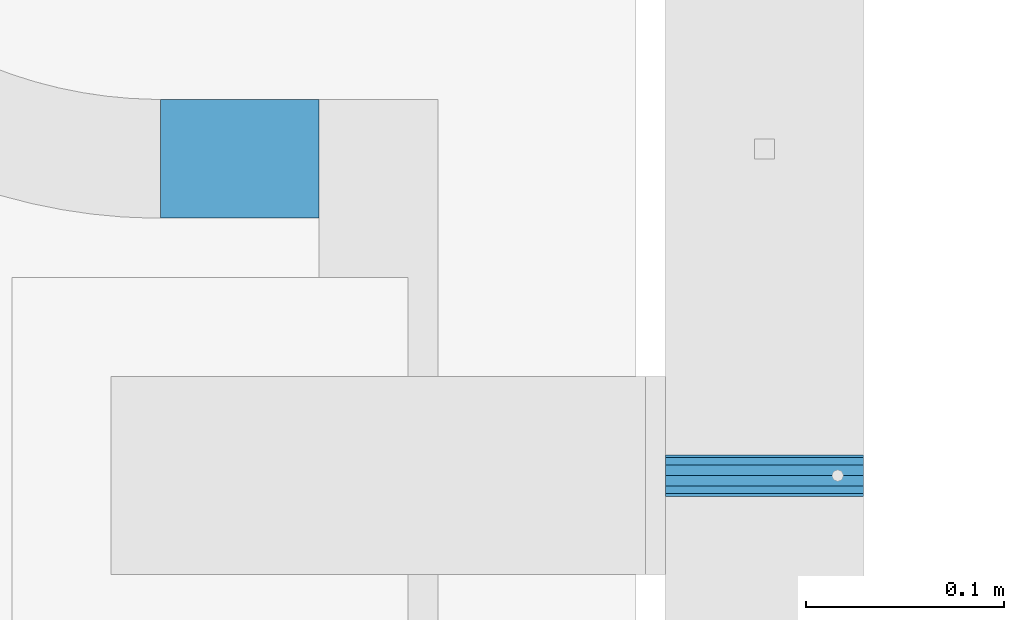
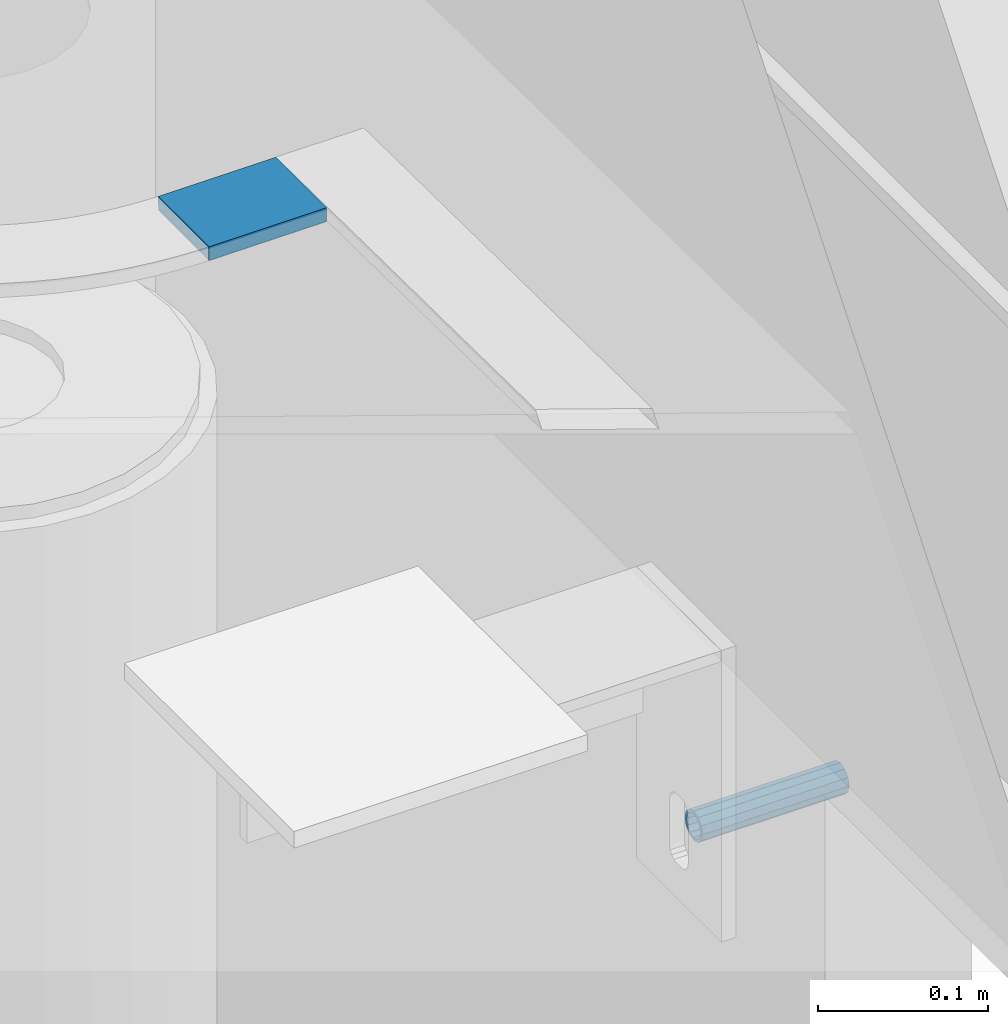
# One storey, part 115 of 264: 2 beams, 3 elements without a shape of their own.
"""IFC2X3 building model written with IfcOpenShell, lengths in millimetres."""

from ifc_helpers import new_model, si_unit, frame, origin_with_axes, place, context, subcontext, project, spatial, faceted_brep, material, type_object, element, aggregate, save


model = new_model("IFC2X3")

# Units and contexts
model_context = context("Model", 3, precision=1e-05, world=origin_with_axes())
body_context = subcontext(model_context, "Body", "Model", "MODEL_VIEW")
ifc_project = project(units=[si_unit("LENGTHUNIT", "METRE", prefix="MILLI"), si_unit("AREAUNIT", "SQUARE_METRE"), si_unit("VOLUMEUNIT", "CUBIC_METRE"), si_unit("MASSUNIT", "GRAM", prefix="KILO"), si_unit("TIMEUNIT", "SECOND"), si_unit("PLANEANGLEUNIT", "RADIAN"), si_unit("SOLIDANGLEUNIT", "STERADIAN"), si_unit("THERMODYNAMICTEMPERATUREUNIT", "DEGREE_CELSIUS"), si_unit("LUMINOUSINTENSITYUNIT", "LUMEN")], contexts=[model_context])

# Site, building, storey
site_placement = place(None, origin_with_axes())
site = spatial("IfcSite", under=ifc_project, at=site_placement, CompositionType="ELEMENT")
building_placement = place(site_placement, origin_with_axes())
building = spatial("IfcBuilding", under=site, at=building_placement, CompositionType="ELEMENT")
storey_placement = place(building_placement, origin_with_axes())
storey = spatial("IfcBuildingStorey", under=building, at=storey_placement, Name="K", CompositionType="ELEMENT", Elevation=0.0)

# Assemblies, beam
assembly_1_placement = place(storey_placement, origin_with_axes())
assembly_1 = element("IfcElementAssembly", 1, at=assembly_1_placement, inside=storey, AssemblyPlace="NOTDEFINED", PredefinedType="REINFORCEMENT_UNIT")
assembly_2_placement = place(assembly_1_placement, origin_with_axes())
assembly_2 = element("IfcElementAssembly", 2, at=assembly_2_placement, Name="Steel Assembly", AssemblyPlace="NOTDEFINED", PredefinedType="RIGID_FRAME")
aggregate(assembly_1, [assembly_2])
ifc_material_1 = material(Name="STEEL/1.4301")
beam_type_1 = type_object("IfcBeamType", PredefinedType="NOTDEFINED")
beam_1_placement = place(assembly_2_placement, frame((35264.9964028739, 22249.9972390075, 81285.0), z_axis=(0.0, -1.0, 0.0), x_axis=(1.0, 0.0, 0.0)))
beam_1 = element("IfcBeam", 3, at=beam_1_placement, type_object=beam_type_1, material=ifc_material_1, context=body_context, shape_type="Brep", body=[
    faceted_brep([(0.0, -8.49999999999272, -1.45519152283669e-11), (0.0, -7.36121593215648, 4.24999999998545), (100.000000000262, -7.36121593215648, 4.24999999998545), (100.000000000262, -8.49999999999272, -1.45519152283669e-11), (0.0, -4.24999999998545, 7.36121593216376), (100.000000000262, -4.24999999998545, 7.36121593216376), (0.0, 1.45519152283669e-11, 8.49999999998545), (100.000000000262, 1.45519152283669e-11, 8.49999999998545), (0.0, 4.25000000001455, 7.36121593216376), (100.000000000262, 4.25000000001455, 7.36121593216376), (0.0, 7.36121593217104, 4.24999999998545), (100.000000000262, 7.36121593217104, 4.24999999998545), (0.0, 8.50000000000728, 0.0), (100.000000000262, 8.50000000000728, 0.0), (0.0, 7.36121593217104, -4.25000000001455), (100.000000000262, 7.36121593217104, -4.25000000001455), (0.0, 4.25000000000728, -7.36121593219286), (100.000000000262, 4.25000000000728, -7.36121593219286), (0.0, 7.27595761418343e-12, -8.5), (100.000000000262, 7.27595761418343e-12, -8.5), (0.0, -4.24999999999272, -7.36121593217831), (100.000000000262, -4.24999999999272, -7.36121593217831), (0.0, -7.36121593215648, -4.25), (100.000000000262, -7.36121593215648, -4.25), (0.0, -10.4999999999927, -1.45519152283669e-11), (0.0, -9.09326673972828, -5.25000000001455), (100.000000000262, -9.09326673972828, -5.25000000001455), (100.000000000262, -10.4999999999927, -1.45519152283669e-11), (0.0, -5.24999999998545, -9.09326673974283), (100.000000000262, -5.24999999998545, -9.09326673974283), (0.0, 7.27595761418343e-12, -10.5), (100.000000000262, 7.27595761418343e-12, -10.5), (0.0, 5.25000000001455, -9.09326673975738), (100.000000000262, 5.25000000001455, -9.09326673975738), (0.0, 9.09326673975011, -5.25000000001455), (100.000000000262, 9.09326673975011, -5.25000000001455), (0.0, 10.5000000000073, -1.45519152283669e-11), (100.000000000262, 10.5000000000073, -1.45519152283669e-11), (0.0, 9.09326673975011, 5.25), (100.000000000262, 9.09326673975011, 5.25), (0.0, 5.25000000000728, 9.09326673972828), (100.000000000262, 5.25000000000728, 9.09326673972828), (0.0, 1.45519152283669e-11, 10.4999999999854), (100.000000000262, 1.45519152283669e-11, 10.4999999999854), (0.0, -5.24999999999272, 9.09326673972828), (100.000000000262, -5.24999999999272, 9.09326673972828), (0.0, -9.09326673972828, 5.24999999998545), (100.000000000262, -9.09326673972828, 5.24999999998545)], [[[0, 1, 2, 3]], [[1, 4, 5, 2]], [[4, 6, 7, 5]], [[6, 8, 9, 7]], [[8, 10, 11, 9]], [[10, 12, 13, 11]], [[12, 14, 15, 13]], [[14, 16, 17, 15]], [[16, 18, 19, 17]], [[18, 20, 21, 19]], [[20, 22, 23, 21]], [[22, 0, 3, 23]], [[24, 25, 26, 27]], [[25, 28, 29, 26]], [[28, 30, 31, 29]], [[30, 32, 33, 31]], [[32, 34, 35, 33]], [[34, 36, 37, 35]], [[36, 38, 39, 37]], [[38, 40, 41, 39]], [[40, 42, 43, 41]], [[42, 44, 45, 43]], [[44, 46, 47, 45]], [[46, 24, 27, 47]], [[29, 31, 33, 35, 37, 39, 41, 43, 45, 47, 27, 26], [5, 7, 9, 11, 13, 15, 17, 19, 21, 23, 3, 2]], [[46, 44, 42, 40, 38, 36, 34, 32, 30, 28, 25, 24], [22, 20, 18, 16, 14, 12, 10, 8, 6, 4, 1, 0]]]),
])
aggregate(assembly_2, [beam_1])

# Assembly, beam
assembly_3_placement = place(storey_placement, origin_with_axes())
assembly_3 = element("IfcElementAssembly", 4, at=assembly_3_placement, inside=storey, AssemblyPlace="NOTDEFINED", PredefinedType="REINFORCEMENT_UNIT")
ifc_material_2 = material(Name="CONCRETE/Concrete_Undefined")
beam_type_2 = type_object("IfcBeamType", PredefinedType="NOTDEFINED")
beam_2_placement = place(assembly_3_placement, frame((35010.002279683, 22410.0178789446, 81707.3588950719), z_axis=(-0.00268578700072087, 6.80000012107549e-08, 0.999996393267587), x_axis=(0.999996392945569, -2.53780000005236e-05, 0.00268578699982978)))
beam_2 = element("IfcBeam", 5, at=beam_2_placement, type_object=beam_type_2, material=ifc_material_2, context=body_context, shape_type="Brep", body=[
    faceted_brep([(2.5465851649642e-11, 29.9999999999982, -4.99999999998545), (-2.91038304567337e-11, 29.9999999999982, 5.0), (80.0148896796745, 29.9999999999964, 4.99999999998545), (80.0148896796454, 29.9999999999964, -5.00000000001455), (-2.5465851649642e-11, -30.0000000000018, 5.0), (80.0148896796745, -30.0000000000036, 4.99999999998545), (2.72848410531878e-11, -30.0000000000018, -4.99999999998545), (80.0148896796527, -30.0000000000036, -5.0)], [[[0, 1, 2, 3]], [[1, 4, 5, 2]], [[4, 6, 7, 5]], [[6, 0, 3, 7]], [[5, 7, 3, 2]], [[6, 4, 1, 0]]]),
])
aggregate(assembly_3, [beam_2])

save(model, "model.ifc")
